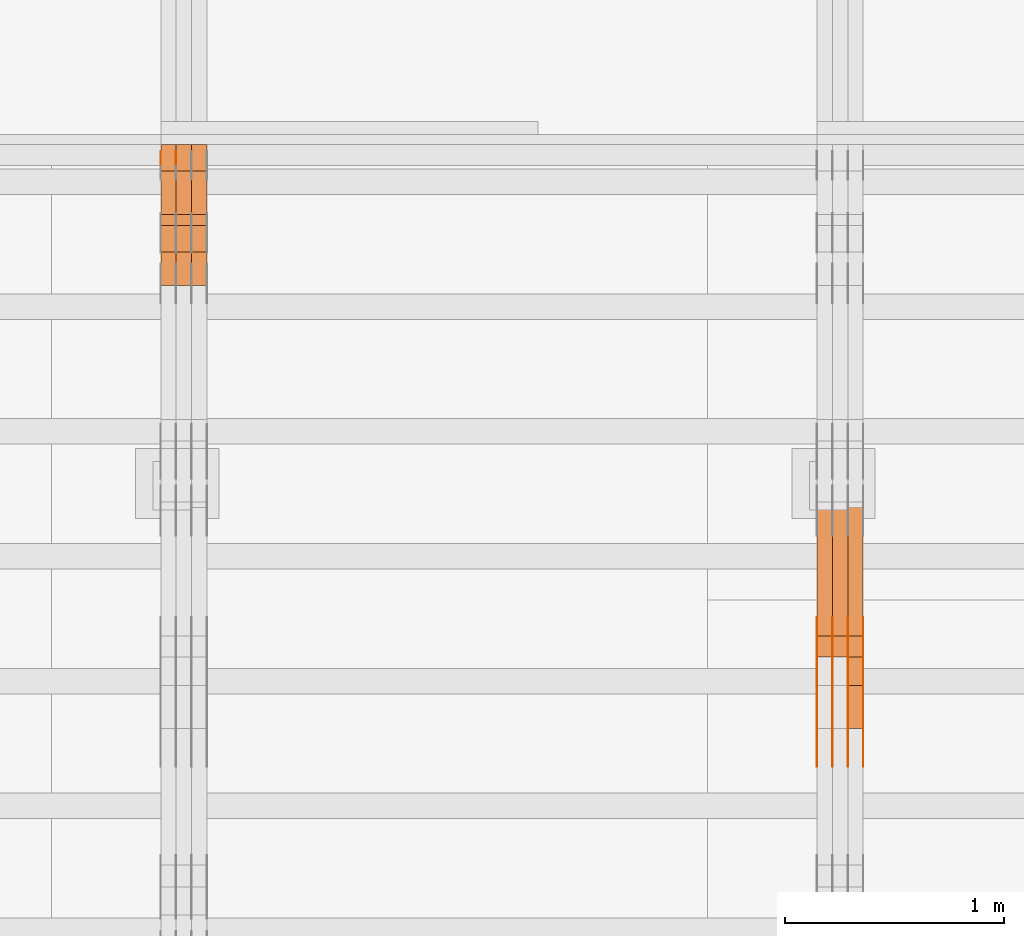
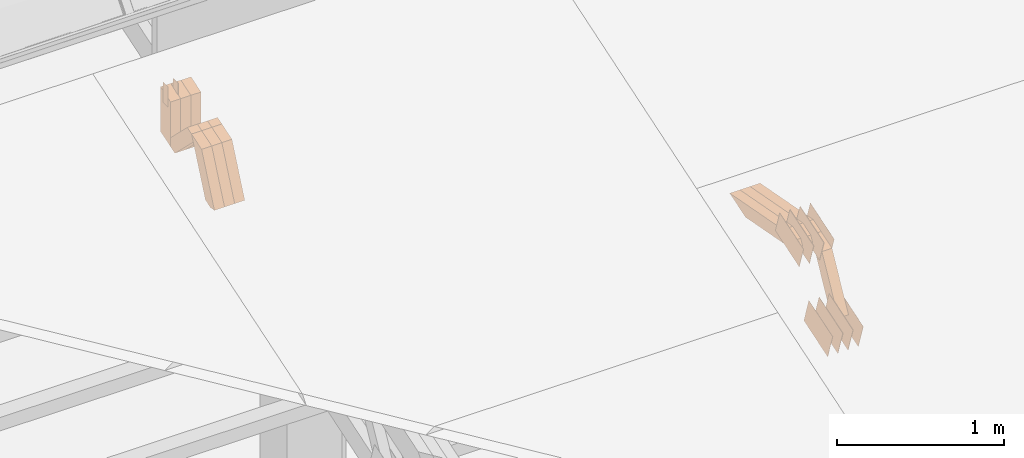
# One storey, part 144 of 385: 28 proxies.
"""IFC2X3 building model written with IfcOpenShell, lengths in millimetres."""

from ifc_helpers import new_model, entity, si_unit, converted_unit, derived_unit, direction, frame, origin, origin_2d_with_axis, place, context, subcontext, project, spatial, polyline, rectangle, outline, extrude, source, transform, mapped, material, type_object, type_shapes, element, save


model = new_model("IFC2X3")

# Units and contexts
model_context = context("Model", 3, precision=0.01, world=origin(), true_north=direction((6.12303176911189e-17, 1.0)))
body_context = subcontext(model_context, "Body", "Model", "MODEL_VIEW")
ifc_project = project(units=[si_unit("LENGTHUNIT", "METRE", prefix="MILLI"), si_unit("AREAUNIT", "SQUARE_METRE"), si_unit("VOLUMEUNIT", "CUBIC_METRE"), converted_unit("PLANEANGLEUNIT", "DEGREE", entity("IfcRatioMeasure", 0.0174532925199433), si_unit("PLANEANGLEUNIT", "RADIAN"), dimensions=[0, 0, 0, 0, 0, 0, 0]), si_unit("MASSUNIT", "GRAM", prefix="KILO"), derived_unit("MASSDENSITYUNIT", [(si_unit("MASSUNIT", "GRAM", prefix="KILO"), 1), (si_unit("LENGTHUNIT", "METRE"), -3)]), si_unit("TIMEUNIT", "SECOND"), si_unit("FREQUENCYUNIT", "HERTZ"), si_unit("THERMODYNAMICTEMPERATUREUNIT", "DEGREE_CELSIUS"), derived_unit("THERMALTRANSMITTANCEUNIT", [(si_unit("MASSUNIT", "GRAM", prefix="KILO"), 1), (si_unit("THERMODYNAMICTEMPERATUREUNIT", "KELVIN"), -1), (si_unit("TIMEUNIT", "SECOND"), -3)]), derived_unit("VOLUMETRICFLOWRATEUNIT", [(si_unit("LENGTHUNIT", "METRE"), 3), (si_unit("TIMEUNIT", "SECOND"), -1)]), si_unit("ELECTRICCURRENTUNIT", "AMPERE"), si_unit("ELECTRICVOLTAGEUNIT", "VOLT"), si_unit("POWERUNIT", "WATT"), si_unit("FORCEUNIT", "NEWTON", prefix="KILO"), si_unit("ILLUMINANCEUNIT", "LUX"), si_unit("LUMINOUSFLUXUNIT", "LUMEN"), si_unit("LUMINOUSINTENSITYUNIT", "CANDELA"), derived_unit("USERDEFINED", [(si_unit("MASSUNIT", "GRAM", prefix="KILO"), -1), (si_unit("LENGTHUNIT", "METRE"), -2), (si_unit("TIMEUNIT", "SECOND"), 3), (si_unit("LUMINOUSFLUXUNIT", "LUMEN"), 1)]), derived_unit("LINEARVELOCITYUNIT", [(si_unit("LENGTHUNIT", "METRE"), 1), (si_unit("TIMEUNIT", "SECOND"), -1)]), si_unit("PRESSUREUNIT", "PASCAL"), derived_unit("USERDEFINED", [(si_unit("LENGTHUNIT", "METRE"), -2), (si_unit("MASSUNIT", "GRAM", prefix="KILO"), 1), (si_unit("TIMEUNIT", "SECOND"), -2)])], contexts=[model_context])

# Site, building, storey
site_placement = place(None, origin())
site = spatial("IfcSite", under=ifc_project, at=site_placement, CompositionType="ELEMENT")
building_placement = place(site_placement, origin())
building = spatial("IfcBuilding", under=site, at=building_placement, CompositionType="ELEMENT")
storey_placement = place(building_placement, origin())
storey = spatial("IfcBuildingStorey", under=building, at=storey_placement, Name="Default", CompositionType="ELEMENT", Elevation=0.0)

# Proxies
ifc_material_1 = material(Name="IfcSurfaceStyle #277320")
building_element_proxy_type_1 = type_object("IfcBuildingElementProxyType", PredefinedType="NOTDEFINED", material=ifc_material_1)
shared_shape_1 = source(origin(), body_context, "Body", "SweptSolid", [
    extrude(outline(polyline([(-149.99966632326, -95.9999759039407), (149.999881095801, -95.9999759039407), (150.000557367591, 95.9999759039407), (-150.000772140132, 95.9999759039406), (-149.99966632326, -95.9999759039407)])), frame((150.000557367591, 96.0004291135906, 0.0), z_axis=(0.0, 0.0, 1.0), x_axis=(-1.0, 0.0, 0.0)), (0.0, 0.0, 1.0), 1.29999999999999),
])
type_shapes(building_element_proxy_type_1, [shared_shape_1])
proxy_1_placement = place(building_placement, frame((21386.3, 10934.7734375, 2766.8759765625), z_axis=(-1.0, 0.0, 0.0), x_axis=(0.0, 0.951056516295124, 0.309016994375039)))
element("IfcBuildingElementProxy", 1, at=proxy_1_placement, inside=storey, type_object=building_element_proxy_type_1, material=ifc_material_1, context=body_context, shape_type="MappedRepresentation", body=[
    mapped(shared_shape_1, transform((0.0, 0.0, 0.0), scale=1.0)),
])
ifc_material_2 = material(Name="IfcSurfaceStyle #277263")
building_element_proxy_type_2 = type_object("IfcBuildingElementProxyType", PredefinedType="NOTDEFINED", material=ifc_material_2)
shared_shape_2 = source(origin(), body_context, "Body", "SweptSolid", [
    extrude(outline(polyline([(-149.99966632326, -95.9999759039407), (149.999881095801, -95.9999759039407), (150.000557367591, 95.9999759039407), (-150.000772140132, 95.9999759039406), (-149.99966632326, -95.9999759039407)])), frame((150.000557367591, 96.0004291135906, 0.0), z_axis=(0.0, 0.0, 1.0), x_axis=(-1.0, 0.0, 0.0)), (0.0, 0.0, 1.0), 1.29999999999999),
])
type_shapes(building_element_proxy_type_2, [shared_shape_2])
proxy_2_placement = place(building_placement, frame((21315.0, 10934.7734375, 2766.8759765625), z_axis=(-1.0, 0.0, 0.0), x_axis=(0.0, 0.951056516295124, 0.309016994375039)))
element("IfcBuildingElementProxy", 2, at=proxy_2_placement, inside=storey, type_object=building_element_proxy_type_2, material=ifc_material_2, context=body_context, shape_type="MappedRepresentation", body=[
    mapped(shared_shape_2, transform((0.0, 0.0, 0.0), scale=1.0)),
])
ifc_material_3 = material(Name="IfcSurfaceStyle #277206")
building_element_proxy_type_3 = type_object("IfcBuildingElementProxyType", PredefinedType="NOTDEFINED", material=ifc_material_3)
shared_shape_3 = source(origin(), body_context, "Body", "SweptSolid", [
    extrude(outline(polyline([(-149.99966632326, -95.9999759039407), (149.999881095801, -95.9999759039407), (150.000557367591, 95.9999759039407), (-150.000772140132, 95.9999759039406), (-149.99966632326, -95.9999759039407)])), frame((150.000557367591, 96.0004291135906, 0.0), z_axis=(0.0, 0.0, 1.0), x_axis=(-1.0, 0.0, 0.0)), (0.0, 0.0, 1.0), 1.29999999999999),
])
type_shapes(building_element_proxy_type_3, [shared_shape_3])
proxy_3_placement = place(building_placement, frame((21316.3, 10934.7734375, 2766.8759765625), z_axis=(-1.0, 0.0, 0.0), x_axis=(0.0, 0.951056516295124, 0.309016994375039)))
element("IfcBuildingElementProxy", 3, at=proxy_3_placement, inside=storey, type_object=building_element_proxy_type_3, material=ifc_material_3, context=body_context, shape_type="MappedRepresentation", body=[
    mapped(shared_shape_3, transform((0.0, 0.0, 0.0), scale=1.0)),
])
ifc_material_4 = material(Name="IfcSurfaceStyle #277149")
building_element_proxy_type_4 = type_object("IfcBuildingElementProxyType", PredefinedType="NOTDEFINED", material=ifc_material_4)
shared_shape_4 = source(origin(), body_context, "Body", "SweptSolid", [
    extrude(outline(polyline([(-149.99966632326, -95.9999759039407), (149.999881095801, -95.9999759039407), (150.000557367591, 95.9999759039407), (-150.000772140132, 95.9999759039406), (-149.99966632326, -95.9999759039407)])), frame((150.000557367591, 96.0004291135906, 0.0), z_axis=(0.0, 0.0, 1.0), x_axis=(-1.0, 0.0, 0.0)), (0.0, 0.0, 1.0), 1.29999999999998),
])
type_shapes(building_element_proxy_type_4, [shared_shape_4])
proxy_4_placement = place(building_placement, frame((21245.0, 10934.7734375, 2766.8759765625), z_axis=(-1.0, 0.0, 0.0), x_axis=(0.0, 0.951056516295124, 0.309016994375039)))
element("IfcBuildingElementProxy", 4, at=proxy_4_placement, inside=storey, type_object=building_element_proxy_type_4, material=ifc_material_4, context=body_context, shape_type="MappedRepresentation", body=[
    mapped(shared_shape_4, transform((0.0, 0.0, 0.0), scale=1.0)),
])
ifc_material_5 = material(Name="IfcSurfaceStyle #277092")
building_element_proxy_type_5 = type_object("IfcBuildingElementProxyType", PredefinedType="NOTDEFINED", material=ifc_material_5)
shared_shape_5 = source(origin(), body_context, "Body", "SweptSolid", [
    extrude(outline(polyline([(-149.99966632326, -95.9999759039407), (149.999881095801, -95.9999759039407), (150.000557367591, 95.9999759039407), (-150.000772140132, 95.9999759039406), (-149.99966632326, -95.9999759039407)])), frame((150.000557367591, 96.0004291135906, 0.0), z_axis=(0.0, 0.0, 1.0), x_axis=(-1.0, 0.0, 0.0)), (0.0, 0.0, 1.0), 1.29999999999998),
])
type_shapes(building_element_proxy_type_5, [shared_shape_5])
proxy_5_placement = place(building_placement, frame((21246.3, 10934.7734375, 2766.8759765625), z_axis=(-1.0, 0.0, 0.0), x_axis=(0.0, 0.951056516295124, 0.309016994375039)))
element("IfcBuildingElementProxy", 5, at=proxy_5_placement, inside=storey, type_object=building_element_proxy_type_5, material=ifc_material_5, context=body_context, shape_type="MappedRepresentation", body=[
    mapped(shared_shape_5, transform((0.0, 0.0, 0.0), scale=1.0)),
])
ifc_material_6 = material(Name="IfcSurfaceStyle #277035")
building_element_proxy_type_6 = type_object("IfcBuildingElementProxyType", PredefinedType="NOTDEFINED", material=ifc_material_6)
shared_shape_6 = source(origin(), body_context, "Body", "SweptSolid", [
    extrude(outline(polyline([(-149.99966632326, -95.9999759039407), (149.999881095801, -95.9999759039407), (150.000557367591, 95.9999759039407), (-150.000772140132, 95.9999759039406), (-149.99966632326, -95.9999759039407)])), frame((150.000557367591, 96.0004291135906, 0.0), z_axis=(0.0, 0.0, 1.0), x_axis=(-1.0, 0.0, 0.0)), (0.0, 0.0, 1.0), 1.29999999999998),
])
type_shapes(building_element_proxy_type_6, [shared_shape_6])
proxy_6_placement = place(building_placement, frame((21175.0, 10934.7734375, 2766.8759765625), z_axis=(-1.0, 0.0, 0.0), x_axis=(0.0, 0.951056516295124, 0.309016994375039)))
element("IfcBuildingElementProxy", 6, at=proxy_6_placement, inside=storey, type_object=building_element_proxy_type_6, material=ifc_material_6, context=body_context, shape_type="MappedRepresentation", body=[
    mapped(shared_shape_6, transform((0.0, 0.0, 0.0), scale=1.0)),
])
ifc_material_7 = material(Name="IfcSurfaceStyle #267744")
building_element_proxy_type_7 = type_object("IfcBuildingElementProxyType", PredefinedType="NOTDEFINED", material=ifc_material_7)
shared_shape_7 = source(origin(), body_context, "Body", "SweptSolid", [
    extrude(outline(polyline([(-150.000273478628, -84.0002987844282), (149.999198496832, -84.0002987844282), (150.000273478627, 84.0002987844282), (-149.999198496831, 84.0002987844282), (-150.000273478628, -84.0002987844282)])), frame((150.000273478627, 84.0002987844282, 0.0), z_axis=(0.0, 0.0, 1.0), x_axis=(-1.0, 0.0, 0.0)), (0.0, 0.0, 1.0), 1.29999999999999),
])
type_shapes(building_element_proxy_type_7, [shared_shape_7])
proxy_7_placement = place(building_placement, frame((21386.3, 11283.0116722926, 3194.09682266857), z_axis=(-1.0, 0.0, 0.0), x_axis=(0.0, 0.951056516295154, 0.309016994374948)))
element("IfcBuildingElementProxy", 7, at=proxy_7_placement, inside=storey, type_object=building_element_proxy_type_7, material=ifc_material_7, context=body_context, shape_type="MappedRepresentation", body=[
    mapped(shared_shape_7, transform((0.0, 0.0, 0.0), scale=1.0)),
])
ifc_material_8 = material(Name="IfcSurfaceStyle #267687")
building_element_proxy_type_8 = type_object("IfcBuildingElementProxyType", PredefinedType="NOTDEFINED", material=ifc_material_8)
shared_shape_8 = source(origin(), body_context, "Body", "SweptSolid", [
    extrude(outline(polyline([(-150.000273478628, -84.0002987844282), (149.999198496832, -84.0002987844282), (150.000273478627, 84.0002987844282), (-149.999198496831, 84.0002987844282), (-150.000273478628, -84.0002987844282)])), frame((150.000273478627, 84.0002987844282, 0.0), z_axis=(0.0, 0.0, 1.0), x_axis=(-1.0, 0.0, 0.0)), (0.0, 0.0, 1.0), 1.29999999999999),
])
type_shapes(building_element_proxy_type_8, [shared_shape_8])
proxy_8_placement = place(building_placement, frame((21315.0, 11283.0116722926, 3194.09682266857), z_axis=(-1.0, 0.0, 0.0), x_axis=(0.0, 0.951056516295154, 0.309016994374948)))
element("IfcBuildingElementProxy", 8, at=proxy_8_placement, inside=storey, type_object=building_element_proxy_type_8, material=ifc_material_8, context=body_context, shape_type="MappedRepresentation", body=[
    mapped(shared_shape_8, transform((0.0, 0.0, 0.0), scale=1.0)),
])
ifc_material_9 = material(Name="IfcSurfaceStyle #267630")
building_element_proxy_type_9 = type_object("IfcBuildingElementProxyType", PredefinedType="NOTDEFINED", material=ifc_material_9)
shared_shape_9 = source(origin(), body_context, "Body", "SweptSolid", [
    extrude(outline(polyline([(-150.000273478628, -84.0002987844282), (149.999198496832, -84.0002987844282), (150.000273478627, 84.0002987844282), (-149.999198496831, 84.0002987844282), (-150.000273478628, -84.0002987844282)])), frame((150.000273478627, 84.0002987844282, 0.0), z_axis=(0.0, 0.0, 1.0), x_axis=(-1.0, 0.0, 0.0)), (0.0, 0.0, 1.0), 1.29999999999999),
])
type_shapes(building_element_proxy_type_9, [shared_shape_9])
proxy_9_placement = place(building_placement, frame((21316.3, 11283.0116722926, 3194.09682266857), z_axis=(-1.0, 0.0, 0.0), x_axis=(0.0, 0.951056516295154, 0.309016994374948)))
element("IfcBuildingElementProxy", 9, at=proxy_9_placement, inside=storey, type_object=building_element_proxy_type_9, material=ifc_material_9, context=body_context, shape_type="MappedRepresentation", body=[
    mapped(shared_shape_9, transform((0.0, 0.0, 0.0), scale=1.0)),
])
ifc_material_10 = material(Name="IfcSurfaceStyle #267573")
building_element_proxy_type_10 = type_object("IfcBuildingElementProxyType", PredefinedType="NOTDEFINED", material=ifc_material_10)
shared_shape_10 = source(origin(), body_context, "Body", "SweptSolid", [
    extrude(outline(polyline([(-150.000273478628, -84.0002987844282), (149.999198496832, -84.0002987844282), (150.000273478627, 84.0002987844282), (-149.999198496831, 84.0002987844282), (-150.000273478628, -84.0002987844282)])), frame((150.000273478627, 84.0002987844282, 0.0), z_axis=(0.0, 0.0, 1.0), x_axis=(-1.0, 0.0, 0.0)), (0.0, 0.0, 1.0), 1.29999999999998),
])
type_shapes(building_element_proxy_type_10, [shared_shape_10])
proxy_10_placement = place(building_placement, frame((21245.0, 11283.0116722926, 3194.09682266857), z_axis=(-1.0, 0.0, 0.0), x_axis=(0.0, 0.951056516295154, 0.309016994374948)))
element("IfcBuildingElementProxy", 10, at=proxy_10_placement, inside=storey, type_object=building_element_proxy_type_10, material=ifc_material_10, context=body_context, shape_type="MappedRepresentation", body=[
    mapped(shared_shape_10, transform((0.0, 0.0, 0.0), scale=1.0)),
])
ifc_material_11 = material(Name="IfcSurfaceStyle #267516")
building_element_proxy_type_11 = type_object("IfcBuildingElementProxyType", PredefinedType="NOTDEFINED", material=ifc_material_11)
shared_shape_11 = source(origin(), body_context, "Body", "SweptSolid", [
    extrude(outline(polyline([(-150.000273478628, -84.0002987844282), (149.999198496832, -84.0002987844282), (150.000273478627, 84.0002987844282), (-149.999198496831, 84.0002987844282), (-150.000273478628, -84.0002987844282)])), frame((150.000273478627, 84.0002987844282, 0.0), z_axis=(0.0, 0.0, 1.0), x_axis=(-1.0, 0.0, 0.0)), (0.0, 0.0, 1.0), 1.29999999999998),
])
type_shapes(building_element_proxy_type_11, [shared_shape_11])
proxy_11_placement = place(building_placement, frame((21246.3, 11283.0116722926, 3194.09682266857), z_axis=(-1.0, 0.0, 0.0), x_axis=(0.0, 0.951056516295154, 0.309016994374948)))
element("IfcBuildingElementProxy", 11, at=proxy_11_placement, inside=storey, type_object=building_element_proxy_type_11, material=ifc_material_11, context=body_context, shape_type="MappedRepresentation", body=[
    mapped(shared_shape_11, transform((0.0, 0.0, 0.0), scale=1.0)),
])
ifc_material_12 = material(Name="IfcSurfaceStyle #267459")
building_element_proxy_type_12 = type_object("IfcBuildingElementProxyType", PredefinedType="NOTDEFINED", material=ifc_material_12)
shared_shape_12 = source(origin(), body_context, "Body", "SweptSolid", [
    extrude(outline(polyline([(-150.000273478628, -84.0002987844282), (149.999198496832, -84.0002987844282), (150.000273478627, 84.0002987844282), (-149.999198496831, 84.0002987844282), (-150.000273478628, -84.0002987844282)])), frame((150.000273478627, 84.0002987844282, 0.0), z_axis=(0.0, 0.0, 1.0), x_axis=(-1.0, 0.0, 0.0)), (0.0, 0.0, 1.0), 1.29999999999998),
])
type_shapes(building_element_proxy_type_12, [shared_shape_12])
proxy_12_placement = place(building_placement, frame((21175.0, 11283.0116722926, 3194.09682266857), z_axis=(-1.0, 0.0, 0.0), x_axis=(0.0, 0.951056516295154, 0.309016994374948)))
element("IfcBuildingElementProxy", 12, at=proxy_12_placement, inside=storey, type_object=building_element_proxy_type_12, material=ifc_material_12, context=body_context, shape_type="MappedRepresentation", body=[
    mapped(shared_shape_12, transform((0.0, 0.0, 0.0), scale=1.0)),
])
ifc_material_13 = material(Name="IfcSurfaceStyle #257448")
building_element_proxy_type_13 = type_object("IfcBuildingElementProxyType", Name="T1-W9 257446", PredefinedType="NOTDEFINED", material=ifc_material_13)
shared_shape_13 = source(origin(), body_context, "Body", "SweptSolid", [
    extrude(outline(polyline([(-287.457507623288, -47.5000268597988), (288.590479960635, -47.5000268597988), (273.55062971372, -2.33146189358546e-05), (186.625054999886, 47.5000385171083), (-461.308657050953, 47.5000385171083), (-287.457507623288, -47.5000268597988)])), frame((288.590945855618, 47.5000968036551, 0.0), z_axis=(0.0, 0.0, 1.0), x_axis=(-1.0, 0.0, 0.0)), (0.0, 0.0, 1.0), 70.0),
])
type_shapes(building_element_proxy_type_13, [shared_shape_13])
proxy_13_placement = place(building_placement, frame((21385.0, 11432.1200855376, 3205.63308612017), z_axis=(-1.0, 0.0, 0.0), x_axis=(0.0, 0.982760503514031, -0.184883186722992)))
element("IfcBuildingElementProxy", 13, at=proxy_13_placement, inside=storey, type_object=building_element_proxy_type_13, material=ifc_material_13, Name="T1-W9", context=body_context, shape_type="MappedRepresentation", body=[
    mapped(shared_shape_13, transform((0.0, 0.0, 0.0), scale=1.0)),
])
ifc_material_14 = material(Name="IfcSurfaceStyle #257382")
building_element_proxy_type_14 = type_object("IfcBuildingElementProxyType", Name="T1-W9 257380", PredefinedType="NOTDEFINED", material=ifc_material_14)
shared_shape_14 = source(origin(), body_context, "Body", "SweptSolid", [
    extrude(outline(polyline([(-287.457507623288, -47.5000268597988), (288.590479960635, -47.5000268597988), (273.55062971372, -2.33146189358546e-05), (186.625054999886, 47.5000385171083), (-461.308657050953, 47.5000385171083), (-287.457507623288, -47.5000268597988)])), frame((288.590945855618, 47.5000968036551, 0.0), z_axis=(0.0, 0.0, 1.0), x_axis=(-1.0, 0.0, 0.0)), (0.0, 0.0, 1.0), 70.0),
])
type_shapes(building_element_proxy_type_14, [shared_shape_14])
proxy_14_placement = place(building_placement, frame((21315.0, 11432.1200855376, 3205.63308612017), z_axis=(-1.0, 0.0, 0.0), x_axis=(0.0, 0.982760503514031, -0.184883186722992)))
element("IfcBuildingElementProxy", 14, at=proxy_14_placement, inside=storey, type_object=building_element_proxy_type_14, material=ifc_material_14, Name="T1-W9", context=body_context, shape_type="MappedRepresentation", body=[
    mapped(shared_shape_14, transform((0.0, 0.0, 0.0), scale=1.0)),
])
ifc_material_15 = material(Name="IfcSurfaceStyle #257316")
building_element_proxy_type_15 = type_object("IfcBuildingElementProxyType", Name="T1-W9 257314", PredefinedType="NOTDEFINED", material=ifc_material_15)
shared_shape_15 = source(origin(), body_context, "Body", "SweptSolid", [
    extrude(outline(polyline([(-287.457507623288, -47.5000268597988), (288.590479960635, -47.5000268597988), (273.55062971372, -2.33146189358546e-05), (186.625054999886, 47.5000385171083), (-461.308657050953, 47.5000385171083), (-287.457507623288, -47.5000268597988)])), frame((288.590945855618, 47.5000968036551, 0.0), z_axis=(0.0, 0.0, 1.0), x_axis=(-1.0, 0.0, 0.0)), (0.0, 0.0, 1.0), 70.0),
])
type_shapes(building_element_proxy_type_15, [shared_shape_15])
proxy_15_placement = place(building_placement, frame((21245.0, 11432.1200855376, 3205.63308612017), z_axis=(-1.0, 0.0, 0.0), x_axis=(0.0, 0.982760503514031, -0.184883186722992)))
element("IfcBuildingElementProxy", 15, at=proxy_15_placement, inside=storey, type_object=building_element_proxy_type_15, material=ifc_material_15, Name="T1-W9", context=body_context, shape_type="MappedRepresentation", body=[
    mapped(shared_shape_15, transform((0.0, 0.0, 0.0), scale=1.0)),
])
ifc_material_16 = material(Name="IfcSurfaceStyle #257052")
building_element_proxy_type_16 = type_object("IfcBuildingElementProxyType", Name="T1-W32 257050", PredefinedType="NOTDEFINED", material=ifc_material_16)
shared_shape_16 = source(origin(), body_context, "Body", "SweptSolid", [
    extrude(outline(polyline([(-312.414547135921, -47.5000544873059), (136.677011757652, -47.5000544873059), (186.250996577889, 0.000369497452627243), (202.753116295831, 47.4998697385796), (-213.26657749545, 47.4998697385796), (-312.414547135921, -47.5000544873059)])), frame((202.753376481939, 47.5001296985553, 0.0), z_axis=(0.0, 0.0, 1.0), x_axis=(-1.0, 0.0, 0.0)), (0.0, 0.0, 1.0), 70.0),
])
type_shapes(building_element_proxy_type_16, [shared_shape_16])
proxy_16_placement = place(building_placement, frame((21385.0, 11110.7808979007, 2747.18129017315), z_axis=(-1.0, 0.0, 0.0), x_axis=(0.0, 0.472919689385906, 0.881105537033526)))
element("IfcBuildingElementProxy", 16, at=proxy_16_placement, inside=storey, type_object=building_element_proxy_type_16, material=ifc_material_16, Name="T1-W32", context=body_context, shape_type="MappedRepresentation", body=[
    mapped(shared_shape_16, transform((0.0, 0.0, 0.0), scale=1.0)),
])
ifc_material_17 = material(Name="IfcSurfaceStyle #234509")
building_element_proxy_type_17 = type_object("IfcBuildingElementProxyType", PredefinedType="NOTDEFINED", material=ifc_material_17)
shared_shape_17 = source(origin(), body_context, "Body", "SweptSolid", [
    extrude(rectangle(XDim=150.0, YDim=60.0, at=origin_2d_with_axis()), frame((75.0000705696166, 30.0, 0.0), z_axis=(0.0, 0.0, 1.0), x_axis=(-1.0, 0.0, 0.0)), (0.0, 0.0, 1.0), 1.29999999999999),
])
type_shapes(building_element_proxy_type_17, [shared_shape_17])
proxy_17_placement = place(building_placement, frame((18245.0, 13750.0, 3972.59919166337), z_axis=(-1.0, 0.0, 0.0), x_axis=(0.0, 0.0, -1.0)))
element("IfcBuildingElementProxy", 17, at=proxy_17_placement, inside=storey, type_object=building_element_proxy_type_17, material=ifc_material_17, context=body_context, shape_type="MappedRepresentation", body=[
    mapped(shared_shape_17, transform((0.0, 0.0, 0.0), scale=1.0)),
])
ifc_material_18 = material(Name="IfcSurfaceStyle #234452")
building_element_proxy_type_18 = type_object("IfcBuildingElementProxyType", PredefinedType="NOTDEFINED", material=ifc_material_18)
shared_shape_18 = source(origin(), body_context, "Body", "SweptSolid", [
    extrude(rectangle(XDim=150.0, YDim=60.0, at=origin_2d_with_axis()), frame((75.0000705696166, 30.0, 0.0), z_axis=(0.0, 0.0, 1.0), x_axis=(-1.0, 0.0, 0.0)), (0.0, 0.0, 1.0), 1.29999999999999),
])
type_shapes(building_element_proxy_type_18, [shared_shape_18])
proxy_18_placement = place(building_placement, frame((18246.3, 13750.0, 3972.59919166337), z_axis=(-1.0, 0.0, 0.0), x_axis=(0.0, 0.0, -1.0)))
element("IfcBuildingElementProxy", 18, at=proxy_18_placement, inside=storey, type_object=building_element_proxy_type_18, material=ifc_material_18, context=body_context, shape_type="MappedRepresentation", body=[
    mapped(shared_shape_18, transform((0.0, 0.0, 0.0), scale=1.0)),
])
ifc_material_19 = material(Name="IfcSurfaceStyle #234395")
building_element_proxy_type_19 = type_object("IfcBuildingElementProxyType", PredefinedType="NOTDEFINED", material=ifc_material_19)
shared_shape_19 = source(origin(), body_context, "Body", "SweptSolid", [
    extrude(rectangle(XDim=150.0, YDim=60.0, at=origin_2d_with_axis()), frame((75.0000705696166, 30.0, 0.0), z_axis=(0.0, 0.0, 1.0), x_axis=(-1.0, 0.0, 0.0)), (0.0, 0.0, 1.0), 1.29999999999999),
])
type_shapes(building_element_proxy_type_19, [shared_shape_19])
proxy_19_placement = place(building_placement, frame((18175.0, 13750.0, 3972.59919166337), z_axis=(-1.0, 0.0, 0.0), x_axis=(0.0, 0.0, -1.0)))
element("IfcBuildingElementProxy", 19, at=proxy_19_placement, inside=storey, type_object=building_element_proxy_type_19, material=ifc_material_19, context=body_context, shape_type="MappedRepresentation", body=[
    mapped(shared_shape_19, transform((0.0, 0.0, 0.0), scale=1.0)),
])
ifc_material_20 = material(Name="IfcSurfaceStyle #225194")
building_element_proxy_type_20 = type_object("IfcBuildingElementProxyType", Name="T1-W49 225192", PredefinedType="NOTDEFINED", material=ifc_material_20)
shared_shape_20 = source(origin(), body_context, "Body", "SweptSolid", [
    extrude(outline(polyline([(-155.175867306415, -47.4997478409253), (152.310664695054, -47.4997478409253), (170.496756790954, -6.14570120142345e-05), (145.70957993751, 47.4998092979374), (-133.37808995724, 47.4998092979373), (-179.963044159863, -6.14570120298391e-05), (-155.175867306415, -47.4997478409253)])), frame((170.496756790954, 47.5001152140455, 0.0), z_axis=(0.0, 0.0, 1.0), x_axis=(-1.0, 0.0, 0.0)), (0.0, 0.0, 1.0), 70.0),
])
type_shapes(building_element_proxy_type_20, [shared_shape_20])
proxy_20_placement = place(building_placement, frame((18385.0, 13443.048524104, 3830.71841973934), z_axis=(-1.0, 0.0, 0.0), x_axis=(0.0, 0.713950095632063, -0.700196587357413)))
element("IfcBuildingElementProxy", 20, at=proxy_20_placement, inside=storey, type_object=building_element_proxy_type_20, material=ifc_material_20, Name="T1-W49", context=body_context, shape_type="MappedRepresentation", body=[
    mapped(shared_shape_20, transform((0.0, 0.0, 0.0), scale=1.0)),
])
ifc_material_21 = material(Name="IfcSurfaceStyle #225119")
building_element_proxy_type_21 = type_object("IfcBuildingElementProxyType", Name="T1-W49 225117", PredefinedType="NOTDEFINED", material=ifc_material_21)
shared_shape_21 = source(origin(), body_context, "Body", "SweptSolid", [
    extrude(outline(polyline([(-155.175867306415, -47.4997478409253), (152.310664695054, -47.4997478409253), (170.496756790954, -6.14570120142345e-05), (145.70957993751, 47.4998092979374), (-133.37808995724, 47.4998092979373), (-179.963044159863, -6.14570120298391e-05), (-155.175867306415, -47.4997478409253)])), frame((170.496756790954, 47.5001152140455, 0.0), z_axis=(0.0, 0.0, 1.0), x_axis=(-1.0, 0.0, 0.0)), (0.0, 0.0, 1.0), 70.0),
])
type_shapes(building_element_proxy_type_21, [shared_shape_21])
proxy_21_placement = place(building_placement, frame((18315.0, 13443.048524104, 3830.71841973934), z_axis=(-1.0, 0.0, 0.0), x_axis=(0.0, 0.713950095632063, -0.700196587357413)))
element("IfcBuildingElementProxy", 21, at=proxy_21_placement, inside=storey, type_object=building_element_proxy_type_21, material=ifc_material_21, Name="T1-W49", context=body_context, shape_type="MappedRepresentation", body=[
    mapped(shared_shape_21, transform((0.0, 0.0, 0.0), scale=1.0)),
])
ifc_material_22 = material(Name="IfcSurfaceStyle #225044")
building_element_proxy_type_22 = type_object("IfcBuildingElementProxyType", Name="T1-W49 225042", PredefinedType="NOTDEFINED", material=ifc_material_22)
shared_shape_22 = source(origin(), body_context, "Body", "SweptSolid", [
    extrude(outline(polyline([(-155.175867306415, -47.4997478409253), (152.310664695054, -47.4997478409253), (170.496756790954, -6.14570120142345e-05), (145.70957993751, 47.4998092979374), (-133.37808995724, 47.4998092979373), (-179.963044159863, -6.14570120298391e-05), (-155.175867306415, -47.4997478409253)])), frame((170.496756790954, 47.5001152140455, 0.0), z_axis=(0.0, 0.0, 1.0), x_axis=(-1.0, 0.0, 0.0)), (0.0, 0.0, 1.0), 70.0),
])
type_shapes(building_element_proxy_type_22, [shared_shape_22])
proxy_22_placement = place(building_placement, frame((18245.0, 13443.048524104, 3830.71841973934), z_axis=(-1.0, 0.0, 0.0), x_axis=(0.0, 0.713950095632063, -0.700196587357413)))
element("IfcBuildingElementProxy", 22, at=proxy_22_placement, inside=storey, type_object=building_element_proxy_type_22, material=ifc_material_22, Name="T1-W49", context=body_context, shape_type="MappedRepresentation", body=[
    mapped(shared_shape_22, transform((0.0, 0.0, 0.0), scale=1.0)),
])
ifc_material_23 = material(Name="IfcSurfaceStyle #224744")
building_element_proxy_type_23 = type_object("IfcBuildingElementProxyType", Name="T1-W1 224742", PredefinedType="NOTDEFINED", material=ifc_material_23)
shared_shape_23 = source(origin(), body_context, "Body", "SweptSolid", [
    extrude(outline(polyline([(-182.839782714844, -60.0), (143.849426269531, -60.0), (182.839660644531, 60.0), (-143.849304199219, 60.0), (-182.839782714844, -60.0)])), frame((182.839674685549, 60.0, 0.0), z_axis=(0.0, 0.0, 1.0), x_axis=(-1.0, 0.0, 0.0)), (0.0, 0.0, 1.0), 70.0),
])
type_shapes(building_element_proxy_type_23, [shared_shape_23])
proxy_23_placement = place(building_placement, frame((18385.0, 13660.0, 3551.41502502148), z_axis=(-1.0, 0.0, 0.0), x_axis=(0.0, 0.0, 1.0)))
element("IfcBuildingElementProxy", 23, at=proxy_23_placement, inside=storey, type_object=building_element_proxy_type_23, material=ifc_material_23, Name="T1-W1", context=body_context, shape_type="MappedRepresentation", body=[
    mapped(shared_shape_23, transform((0.0, 0.0, 0.0), scale=1.0)),
])
ifc_material_24 = material(Name="IfcSurfaceStyle #224687")
building_element_proxy_type_24 = type_object("IfcBuildingElementProxyType", Name="T1-W1 224685", PredefinedType="NOTDEFINED", material=ifc_material_24)
shared_shape_24 = source(origin(), body_context, "Body", "SweptSolid", [
    extrude(outline(polyline([(-182.839782714844, -60.0), (143.849426269531, -60.0), (182.839660644531, 60.0), (-143.849304199219, 60.0), (-182.839782714844, -60.0)])), frame((182.839674685549, 60.0, 0.0), z_axis=(0.0, 0.0, 1.0), x_axis=(-1.0, 0.0, 0.0)), (0.0, 0.0, 1.0), 70.0),
])
type_shapes(building_element_proxy_type_24, [shared_shape_24])
proxy_24_placement = place(building_placement, frame((18315.0, 13660.0, 3551.41502502148), z_axis=(-1.0, 0.0, 0.0), x_axis=(0.0, 0.0, 1.0)))
element("IfcBuildingElementProxy", 24, at=proxy_24_placement, inside=storey, type_object=building_element_proxy_type_24, material=ifc_material_24, Name="T1-W1", context=body_context, shape_type="MappedRepresentation", body=[
    mapped(shared_shape_24, transform((0.0, 0.0, 0.0), scale=1.0)),
])
ifc_material_25 = material(Name="IfcSurfaceStyle #224630")
building_element_proxy_type_25 = type_object("IfcBuildingElementProxyType", Name="T1-W1 224628", PredefinedType="NOTDEFINED", material=ifc_material_25)
shared_shape_25 = source(origin(), body_context, "Body", "SweptSolid", [
    extrude(outline(polyline([(-182.839782714844, -60.0), (143.849426269531, -60.0), (182.839660644531, 60.0), (-143.849304199219, 60.0), (-182.839782714844, -60.0)])), frame((182.839674685549, 60.0, 0.0), z_axis=(0.0, 0.0, 1.0), x_axis=(-1.0, 0.0, 0.0)), (0.0, 0.0, 1.0), 70.0),
])
type_shapes(building_element_proxy_type_25, [shared_shape_25])
proxy_25_placement = place(building_placement, frame((18245.0, 13660.0, 3551.41502502148), z_axis=(-1.0, 0.0, 0.0), x_axis=(0.0, 0.0, 1.0)))
element("IfcBuildingElementProxy", 25, at=proxy_25_placement, inside=storey, type_object=building_element_proxy_type_25, material=ifc_material_25, Name="T1-W1", context=body_context, shape_type="MappedRepresentation", body=[
    mapped(shared_shape_25, transform((0.0, 0.0, 0.0), scale=1.0)),
])
ifc_material_26 = material(Name="IfcSurfaceStyle #224204")
building_element_proxy_type_26 = type_object("IfcBuildingElementProxyType", Name="T1-W42 224202", PredefinedType="NOTDEFINED", material=ifc_material_26)
shared_shape_26 = source(origin(), body_context, "Body", "SweptSolid", [
    extrude(outline(polyline([(-284.837590197601, -47.4997543607933), (129.95880168156, -47.4997543607933), (171.972324990451, 0.000162623346093338), (183.717007105413, 47.4996730491203), (-200.810543579822, 47.4996730491203), (-284.837590197601, -47.4997543607933)])), frame((183.717155718752, 47.4999821655365, 0.0), z_axis=(0.0, 0.0, 1.0), x_axis=(-1.0, 0.0, 0.0)), (0.0, 0.0, 1.0), 70.0),
])
type_shapes(building_element_proxy_type_26, [shared_shape_26])
proxy_26_placement = place(building_placement, frame((18385.0, 13135.8834463264, 3404.958483022), z_axis=(-1.0, 0.0, 0.0), x_axis=(0.0, 0.398630596470292, 0.917111578575769)))
element("IfcBuildingElementProxy", 26, at=proxy_26_placement, inside=storey, type_object=building_element_proxy_type_26, material=ifc_material_26, Name="T1-W42", context=body_context, shape_type="MappedRepresentation", body=[
    mapped(shared_shape_26, transform((0.0, 0.0, 0.0), scale=1.0)),
])
ifc_material_27 = material(Name="IfcSurfaceStyle #224138")
building_element_proxy_type_27 = type_object("IfcBuildingElementProxyType", Name="T1-W42 224136", PredefinedType="NOTDEFINED", material=ifc_material_27)
shared_shape_27 = source(origin(), body_context, "Body", "SweptSolid", [
    extrude(outline(polyline([(-284.837590197601, -47.4997543607933), (129.95880168156, -47.4997543607933), (171.972324990451, 0.000162623346093338), (183.717007105413, 47.4996730491203), (-200.810543579822, 47.4996730491203), (-284.837590197601, -47.4997543607933)])), frame((183.717155718752, 47.4999821655365, 0.0), z_axis=(0.0, 0.0, 1.0), x_axis=(-1.0, 0.0, 0.0)), (0.0, 0.0, 1.0), 70.0),
])
type_shapes(building_element_proxy_type_27, [shared_shape_27])
proxy_27_placement = place(building_placement, frame((18315.0, 13135.8834463264, 3404.958483022), z_axis=(-1.0, 0.0, 0.0), x_axis=(0.0, 0.398630596470292, 0.917111578575769)))
element("IfcBuildingElementProxy", 27, at=proxy_27_placement, inside=storey, type_object=building_element_proxy_type_27, material=ifc_material_27, Name="T1-W42", context=body_context, shape_type="MappedRepresentation", body=[
    mapped(shared_shape_27, transform((0.0, 0.0, 0.0), scale=1.0)),
])
ifc_material_28 = material(Name="IfcSurfaceStyle #224072")
building_element_proxy_type_28 = type_object("IfcBuildingElementProxyType", Name="T1-W42 224070", PredefinedType="NOTDEFINED", material=ifc_material_28)
shared_shape_28 = source(origin(), body_context, "Body", "SweptSolid", [
    extrude(outline(polyline([(-284.837590197601, -47.4997543607933), (129.95880168156, -47.4997543607933), (171.972324990451, 0.000162623346093338), (183.717007105413, 47.4996730491203), (-200.810543579822, 47.4996730491203), (-284.837590197601, -47.4997543607933)])), frame((183.717155718752, 47.4999821655365, 0.0), z_axis=(0.0, 0.0, 1.0), x_axis=(-1.0, 0.0, 0.0)), (0.0, 0.0, 1.0), 70.0),
])
type_shapes(building_element_proxy_type_28, [shared_shape_28])
proxy_28_placement = place(building_placement, frame((18245.0, 13135.8834463264, 3404.958483022), z_axis=(-1.0, 0.0, 0.0), x_axis=(0.0, 0.398630596470292, 0.917111578575769)))
element("IfcBuildingElementProxy", 28, at=proxy_28_placement, inside=storey, type_object=building_element_proxy_type_28, material=ifc_material_28, Name="T1-W42", context=body_context, shape_type="MappedRepresentation", body=[
    mapped(shared_shape_28, transform((0.0, 0.0, 0.0), scale=1.0)),
])

save(model, "model.ifc")
